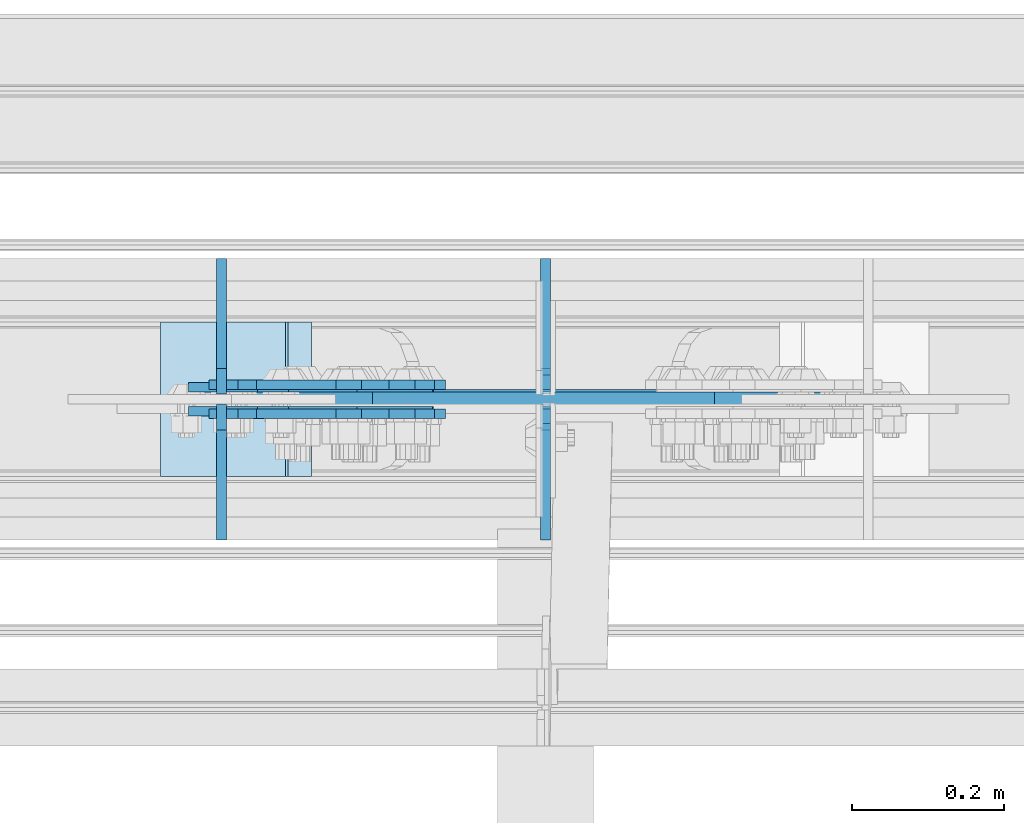
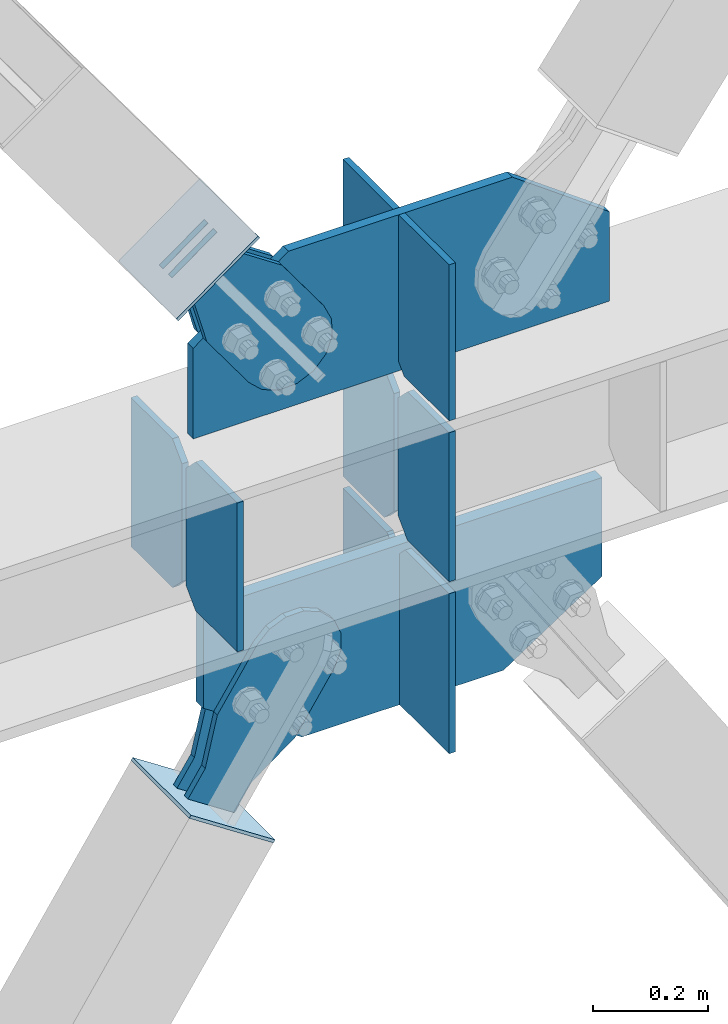
# One storey, part 3647 of 3843: 16 plates, 7 elements without a shape of their own.
"""IFC2X3 building model written with IfcOpenShell, lengths in millimetres."""

from ifc_helpers import new_model, si_unit, frame, origin_with_axes, place, context, subcontext, project, spatial, faceted_brep, material, type_object, element, aggregate, save


model = new_model("IFC2X3")

# Units and contexts
model_context = context("Model", 3, precision=1e-05, world=origin_with_axes())
body_context = subcontext(model_context, "Body", "Model", "MODEL_VIEW")
ifc_project = project(units=[si_unit("LENGTHUNIT", "METRE", prefix="MILLI"), si_unit("AREAUNIT", "SQUARE_METRE"), si_unit("VOLUMEUNIT", "CUBIC_METRE"), si_unit("MASSUNIT", "GRAM", prefix="KILO"), si_unit("TIMEUNIT", "SECOND"), si_unit("PLANEANGLEUNIT", "RADIAN"), si_unit("SOLIDANGLEUNIT", "STERADIAN"), si_unit("THERMODYNAMICTEMPERATUREUNIT", "DEGREE_CELSIUS"), si_unit("LUMINOUSINTENSITYUNIT", "LUMEN")], contexts=[model_context])

# Site, building, storey
site_placement = place(None, origin_with_axes())
site = spatial("IfcSite", under=ifc_project, at=site_placement, CompositionType="ELEMENT")
building_placement = place(site_placement, origin_with_axes())
building = spatial("IfcBuilding", under=site, at=building_placement, Name="Undefined", CompositionType="ELEMENT")
storey_placement = place(building_placement, origin_with_axes())
storey = spatial("IfcBuildingStorey", under=building, at=storey_placement, Name="Undefined", CompositionType="ELEMENT", Elevation=0.0)

# Assembly, plates
assembly_1_placement = place(storey_placement, origin_with_axes())
assembly_1 = element("IfcElementAssembly", 1, at=assembly_1_placement, inside=storey, Name="BEAM", AssemblyPlace="NOTDEFINED", PredefinedType="RIGID_FRAME")
ifc_material_1 = material(Name="STEEL/A572-50")
plate_type_1 = type_object("IfcPlateType", PredefinedType="NOTDEFINED")
plate_1_placement = place(assembly_1_placement, frame((80903.4641858708, 104566.24375, 36093.4), z_axis=(0.0, 1.0, 0.0), x_axis=(0.0, 0.0, 1.0)))
plate_1 = element("IfcPlate", 2, at=plate_1_placement, type_object=plate_type_1, material=ifc_material_1, Name="CB_BEAM", context=body_context, shape_type="Brep", body=[
    faceted_brep([(0.0, -6.34999999999854, 33.3375015258789), (0.0, -6.34999999999854, 178.59375), (0.0, 6.34999999999854, 178.59375), (0.0, 6.34999999999854, 33.3375015258789), (317.499999999985, -6.34999999999854, 178.59375), (317.499999999985, 6.34999999999854, 178.59375), (317.499999999985, -6.34999999999854, 33.3375015258789), (317.499999999985, 6.34999999999854, 33.3375015258789), (284.162498474107, -6.34999999999854, 0.0), (284.162498474107, 6.34999999999854, 0.0), (33.3375015258789, -6.34999999999854, 0.0), (33.3375015258789, 6.34999999999854, 0.0)], [[[0, 1, 2, 3]], [[1, 4, 5, 2]], [[4, 6, 7, 5]], [[6, 8, 9, 7]], [[8, 10, 11, 9]], [[10, 0, 3, 11]], [[5, 7, 9, 11, 3, 2]], [[10, 8, 6, 4, 1, 0]]]),
])
plate_2_placement = place(assembly_1_placement, frame((80903.4641858708, 104551.95625, 36093.4), z_axis=(0.0, -1.0, 0.0), x_axis=(0.0, 0.0, 1.0)))
plate_2 = element("IfcPlate", 3, at=plate_2_placement, type_object=plate_type_1, material=ifc_material_1, Name="CB_BEAM", context=body_context, shape_type="Brep", body=[
    faceted_brep([(0.0, -6.34999999999854, 33.3375015258789), (0.0, -6.34999999999854, 178.59375), (0.0, 6.34999999999854, 178.59375), (0.0, 6.34999999999854, 33.3375015258789), (317.499999999985, -6.34999999999854, 178.59375), (317.499999999985, 6.34999999999854, 178.59375), (317.499999999985, -6.34999999999854, 33.3375015258789), (317.499999999985, 6.34999999999854, 33.3375015258789), (284.162498474107, -6.34999999999854, 0.0), (284.162498474107, 6.34999999999854, 0.0), (33.3375015258789, -6.34999999999854, 0.0), (33.3375015258789, 6.34999999999854, 0.0)], [[[0, 1, 2, 3]], [[1, 4, 5, 2]], [[4, 6, 7, 5]], [[6, 8, 9, 7]], [[8, 10, 11, 9]], [[10, 0, 3, 11]], [[5, 7, 9, 11, 3, 2]], [[10, 8, 6, 4, 1, 0]]]),
])
plate_3_placement = place(assembly_1_placement, frame((81330.8000009417, 104566.24375, 36093.4), z_axis=(0.0, 1.0, 0.0), x_axis=(0.0, 0.0, 1.0)))
plate_3 = element("IfcPlate", 4, at=plate_3_placement, type_object=plate_type_1, material=ifc_material_1, Name="CB_BEAM", context=body_context, shape_type="Brep", body=[
    faceted_brep([(0.0, -6.34999999999854, 33.3375015258789), (0.0, -6.34999999999854, 178.59375), (0.0, 6.34999999999854, 178.59375), (0.0, 6.34999999999854, 33.3375015258789), (317.499999999985, -6.34999999999854, 178.59375), (317.499999999985, 6.34999999999854, 178.59375), (317.499999999985, -6.34999999999854, 33.3375015258789), (317.499999999985, 6.34999999999854, 33.3375015258789), (284.162498474107, -6.34999999999854, 0.0), (284.162498474107, 6.34999999999854, 0.0), (33.3375015258789, -6.34999999999854, 0.0), (33.3375015258789, 6.34999999999854, 0.0)], [[[0, 1, 2, 3]], [[1, 4, 5, 2]], [[4, 6, 7, 5]], [[6, 8, 9, 7]], [[8, 10, 11, 9]], [[10, 0, 3, 11]], [[5, 7, 9, 11, 3, 2]], [[10, 8, 6, 4, 1, 0]]]),
])
plate_4_placement = place(assembly_1_placement, frame((81330.8000009417, 104551.95625, 36093.4), z_axis=(0.0, -1.0, 0.0), x_axis=(0.0, 0.0, 1.0)))
plate_4 = element("IfcPlate", 5, at=plate_4_placement, type_object=plate_type_1, material=ifc_material_1, Name="CB_BEAM", context=body_context, shape_type="Brep", body=[
    faceted_brep([(0.0, -6.34999999999854, 33.3375015258789), (0.0, -6.34999999999854, 178.59375), (0.0, 6.34999999999854, 178.59375), (0.0, 6.34999999999854, 33.3375015258789), (317.499999999985, -6.34999999999854, 178.59375), (317.499999999985, 6.34999999999854, 178.59375), (317.499999999985, -6.34999999999854, 33.3375015258789), (317.499999999985, 6.34999999999854, 33.3375015258789), (284.162498474107, -6.34999999999854, 0.0), (284.162498474107, 6.34999999999854, 0.0), (33.3375015258789, -6.34999999999854, 0.0), (33.3375015258789, 6.34999999999854, 0.0)], [[[0, 1, 2, 3]], [[1, 4, 5, 2]], [[4, 6, 7, 5]], [[6, 8, 9, 7]], [[8, 10, 11, 9]], [[10, 0, 3, 11]], [[5, 7, 9, 11, 3, 2]], [[10, 8, 6, 4, 1, 0]]]),
])
plate_type_2 = type_object("IfcPlateType", PredefinedType="NOTDEFINED")
plate_5_placement = place(assembly_1_placement, frame((81330.8000009417, 104571.8, 35726.6875), z_axis=(0.0, 1.0, 0.0), x_axis=(0.0, 0.0, 1.0)))
plate_5 = element("IfcPlate", 6, at=plate_5_placement, type_object=plate_type_2, material=ifc_material_1, Name="CB", context=body_context, shape_type="Brep", body=[
    faceted_brep([(0.0, -6.3499999046162, 0.0), (0.0, -6.34999999999854, 173.037500000006), (0.0, 6.34999999999854, 173.037500000006), (7.27595761418343e-12, 6.3499999046162, 0.0), (341.302418280502, -6.35000000000582, 173.037500000006), (341.302418280502, 6.35000000000582, 173.037500000006), (341.302418280502, -6.35000000000582, 19.0499992370605), (341.302418280502, 6.35000000000582, 19.0499992370605), (322.252419043441, -6.35000000000582, 0.0), (322.252419043441, 6.35000000000582, 0.0)], [[[0, 1, 2, 3]], [[1, 4, 5, 2]], [[4, 6, 7, 5]], [[6, 8, 9, 7]], [[8, 0, 3, 9]], [[5, 7, 9, 3, 2]], [[8, 6, 4, 1, 0]]]),
])
plate_6_placement = place(assembly_1_placement, frame((81330.8000009417, 104546.4, 35726.6875), z_axis=(0.0, -1.0, 0.0), x_axis=(0.0, 0.0, 1.0)))
plate_6 = element("IfcPlate", 7, at=plate_6_placement, type_object=plate_type_2, material=ifc_material_1, Name="CB", context=body_context, shape_type="Brep", body=[
    faceted_brep([(0.0, -6.3499999046162, 0.0), (0.0, -6.34999999999854, 173.037500000006), (0.0, 6.34999999999854, 173.037500000006), (7.27595761418343e-12, 6.3499999046162, 0.0), (341.302418280502, -6.35000000000582, 173.037500000006), (341.302418280502, 6.35000000000582, 173.037500000006), (341.302418280502, -6.35000000000582, 19.0499992370605), (341.302418280502, 6.35000000000582, 19.0499992370605), (322.252419043441, -6.35000000000582, 0.0), (322.252419043441, 6.35000000000582, 0.0)], [[[0, 1, 2, 3]], [[1, 4, 5, 2]], [[4, 6, 7, 5]], [[6, 8, 9, 7]], [[8, 0, 3, 9]], [[5, 7, 9, 3, 2]], [[8, 6, 4, 1, 0]]]),
])
plate_type_3 = type_object("IfcPlateType", PredefinedType="NOTDEFINED")
plate_7_placement = place(assembly_1_placement, frame((80909.8138656546, 104559.1, 36436.3), z_axis=(1.0, 0.0, 0.0), x_axis=(0.0, 0.0, 1.0)))
plate_7 = element("IfcPlate", 8, at=plate_7_placement, type_object=plate_type_3, material=ifc_material_1, Name="CB", context=body_context, shape_type="Brep", body=[
    faceted_brep([(0.0, -9.52500000000146, 0.0), (0.0, -9.52499999999418, 840.106454561566), (0.0, 9.52499999999418, 840.106454561566), (0.0, 9.52500000000146, 0.0), (190.305685780353, -9.52499999999418, 840.106454561566), (190.305685780353, 9.52499999999418, 840.106454561566), (332.810611949739, -9.52499999999418, 643.900231879976), (332.810611949739, 9.52499999999418, 643.900231879976), (332.810611949739, -9.52499999999418, 427.336135287071), (332.810611949739, 9.52499999999418, 427.336135287071), (332.810611949739, -9.52499999999418, 192.669227863458), (332.810611949739, 9.52499999999418, 192.669227863458), (192.874611365543, -9.52499999999418, 0.0), (192.874611365543, 9.52499999999418, 0.0)], [[[0, 1, 2, 3]], [[1, 4, 5, 2]], [[4, 6, 7, 5]], [[6, 8, 9, 7]], [[8, 10, 11, 9]], [[10, 12, 13, 11]], [[12, 0, 3, 13]], [[5, 7, 9, 11, 13, 3, 2]], [[12, 10, 8, 6, 4, 1, 0]]]),
])

# Assembly, plate
assembly_2_placement = place(storey_placement, origin_with_axes())
assembly_2 = element("IfcElementAssembly", 9, at=assembly_2_placement, inside=storey, Name="Plate", AssemblyPlace="NOTDEFINED", PredefinedType="RIGID_FRAME")
ifc_material_2 = material(Name="STEEL/A36")
plate_type_4 = type_object("IfcPlateType", PredefinedType="NOTDEFINED")
plate_8_placement = place(assembly_2_placement, frame((80825.0548352249, 104660.7, 36775.5895057163), z_axis=(0.809109618324204, 0.0, 0.58765774523549), x_axis=(0.0, -1.0, 0.0)))
plate_8 = element("IfcPlate", 10, at=plate_8_placement, type_object=plate_type_4, material=ifc_material_2, Name="Plate", context=body_context, shape_type="Brep", body=[
    faceted_brep([(0.0, -3.17499999999927, 0.0), (0.0, -3.17500000043947, 203.200000001736), (0.0, 3.1749999995518, 203.200000001743), (0.0, 3.17499999999927, 0.0), (203.200000000012, -3.17500000043947, 203.200000001736), (203.200000000012, 3.1749999995518, 203.200000001743), (203.199996948242, -3.17499999999927, 0.0), (203.199996948242, 3.17499999999927, 0.0)], [[[0, 1, 2, 3]], [[1, 4, 5, 2]], [[4, 6, 7, 5]], [[6, 0, 3, 7]], [[5, 7, 3, 2]], [[6, 4, 1, 0]]]),
])
aggregate(assembly_2, [plate_8])

assembly_3_placement = place(storey_placement, origin_with_axes())
assembly_3 = element("IfcElementAssembly", 11, at=assembly_3_placement, inside=storey, Name="Plate", AssemblyPlace="NOTDEFINED", PredefinedType="RIGID_FRAME")
plate_9_placement = place(assembly_3_placement, frame((81020.3403620731, 104457.5, 35595.744008217), z_axis=(-0.835270498690032, 0.0, 0.549839243795953), x_axis=(0.0, 1.0, 0.0)))
plate_9 = element("IfcPlate", 12, at=plate_9_placement, type_object=plate_type_4, material=ifc_material_2, Name="Plate", context=body_context, shape_type="Brep", body=[
    faceted_brep([(0.0, -3.17499999999927, 0.0), (0.0, -3.17500000043947, 203.200000001736), (0.0, 3.1749999995518, 203.200000001743), (0.0, 3.17499999999927, 0.0), (203.200000000012, -3.17500000043947, 203.200000001736), (203.200000000012, 3.1749999995518, 203.200000001743), (203.199996948242, -3.17499999999927, 0.0), (203.199996948242, 3.17499999999927, 0.0)], [[[0, 1, 2, 3]], [[1, 4, 5, 2]], [[4, 6, 7, 5]], [[6, 0, 3, 7]], [[5, 7, 3, 2]], [[6, 4, 1, 0]]]),
])
aggregate(assembly_3, [plate_9])

assembly_4_placement = place(storey_placement, origin_with_axes())
assembly_4 = element("IfcElementAssembly", 13, at=assembly_4_placement, inside=storey, AssemblyPlace="NOTDEFINED", PredefinedType="RIGID_FRAME")
plate_type_5 = type_object("IfcPlateType", PredefinedType="NOTDEFINED")
plate_10_placement = place(assembly_4_placement, frame((80950.7795124551, 104574.975, 36870.8276274707), z_axis=(-0.80910961832422, 0.0, -0.587657745235469), x_axis=(0.587657745235471, 0.0, -0.809109618324219)))
plate_10 = element("IfcPlate", 14, at=plate_10_placement, type_object=plate_type_5, material=ifc_material_2, context=body_context, shape_type="Brep", body=[
    faceted_brep([(0.0, -6.3499999046162, 0.0), (4.9622030928731e-09, -6.35000000000582, 112.184930798256), (4.9622030928731e-09, 6.35000000000582, 112.184930798256), (7.27595761418343e-12, 6.3499999046162, 0.0), (69.8500000038475, -6.35000000000582, 112.184930798168), (69.8500000038475, 6.35000000000582, 112.184930798168), (171.450000003882, -6.35000000000582, 149.754965398664), (171.450000003882, 6.35000000000582, 149.754965398664), (315.219242329083, -6.35000000000582, 149.754965398519), (315.219242329083, 6.35000000000582, 149.754965398519), (351.06232873004, -6.35000000000582, 142.625332228003), (351.06232873004, 6.35000000000582, 142.625332228003), (381.448630144558, -6.35000000000582, 122.321854736569), (381.448630144558, 6.35000000000582, 122.321854736569), (401.752107634529, -6.35000000000582, 91.9355533209819), (401.752107634529, 6.35000000000582, 91.9355533209819), (408.881740803365, -6.35000000000582, 56.0924638688084), (408.881740803365, 6.35000000000582, 56.0924638688084), (401.75210763223, -6.35000000000582, 20.2493774701215), (401.75210763223, 6.35000000000582, 20.2493774701215), (381.448630141909, -6.35000000000582, -10.1369239423584), (381.448630141909, 6.35000000000582, -10.1369239423584), (351.062328728673, -6.35000000000582, -30.4404014313986), (351.062328728673, 6.35000000000582, -30.4404014313986), (315.219240800725, -6.35000000000582, -37.5700346009617), (315.219240800725, 6.35000000000582, -37.5700346009617), (171.449999995632, -6.35000000000582, -37.5700346008307), (171.449999995632, 6.35000000000582, -37.5700346008307), (69.8499999985434, -6.35000000000582, -8.73114913702011e-11), (69.8499999985434, 6.35000000000582, -8.73114913702011e-11)], [[[0, 1, 2, 3]], [[1, 4, 5, 2]], [[4, 6, 7, 5]], [[6, 8, 9, 7]], [[8, 10, 11, 9]], [[10, 12, 13, 11]], [[12, 14, 15, 13]], [[14, 16, 17, 15]], [[16, 18, 19, 17]], [[18, 20, 21, 19]], [[20, 22, 23, 21]], [[22, 24, 25, 23]], [[24, 26, 27, 25]], [[26, 28, 29, 27]], [[28, 0, 3, 29]], [[5, 7, 9, 11, 13, 15, 17, 19, 21, 23, 25, 27, 29, 3, 2]], [[28, 26, 24, 22, 20, 18, 16, 14, 12, 10, 8, 6, 4, 1, 0]]]),
])
aggregate(assembly_4, [plate_10])

assembly_5_placement = place(storey_placement, origin_with_axes())
assembly_5 = element("IfcElementAssembly", 15, at=assembly_5_placement, inside=storey, AssemblyPlace="NOTDEFINED", PredefinedType="RIGID_FRAME")
plate_11_placement = place(assembly_5_placement, frame((80950.7795124551, 104543.225, 36870.8276274707), z_axis=(-0.80910961832422, 0.0, -0.587657745235469), x_axis=(0.587657745235471, 0.0, -0.809109618324219)))
plate_11 = element("IfcPlate", 16, at=plate_11_placement, type_object=plate_type_5, material=ifc_material_2, context=body_context, shape_type="Brep", body=[
    faceted_brep([(0.0, -6.3499999046162, 0.0), (4.9622030928731e-09, -6.35000000000582, 112.184930798256), (4.9622030928731e-09, 6.35000000000582, 112.184930798256), (7.27595761418343e-12, 6.3499999046162, 0.0), (69.8500000038475, -6.35000000000582, 112.184930798168), (69.8500000038475, 6.35000000000582, 112.184930798168), (171.450000003882, -6.35000000000582, 149.754965398664), (171.450000003882, 6.35000000000582, 149.754965398664), (315.219242329083, -6.35000000000582, 149.754965398519), (315.219242329083, 6.35000000000582, 149.754965398519), (351.06232873004, -6.35000000000582, 142.625332228003), (351.06232873004, 6.35000000000582, 142.625332228003), (381.448630144558, -6.35000000000582, 122.321854736569), (381.448630144558, 6.35000000000582, 122.321854736569), (401.752107634529, -6.35000000000582, 91.9355533209819), (401.752107634529, 6.35000000000582, 91.9355533209819), (408.881740803365, -6.35000000000582, 56.0924638688084), (408.881740803365, 6.35000000000582, 56.0924638688084), (401.75210763223, -6.35000000000582, 20.2493774701215), (401.75210763223, 6.35000000000582, 20.2493774701215), (381.448630141909, -6.35000000000582, -10.1369239423584), (381.448630141909, 6.35000000000582, -10.1369239423584), (351.062328728673, -6.35000000000582, -30.4404014313986), (351.062328728673, 6.35000000000582, -30.4404014313986), (315.219240800725, -6.35000000000582, -37.5700346009617), (315.219240800725, 6.35000000000582, -37.5700346009617), (171.449999995632, -6.35000000000582, -37.5700346008307), (171.449999995632, 6.35000000000582, -37.5700346008307), (69.8499999985434, -6.35000000000582, -8.73114913702011e-11), (69.8499999985434, 6.35000000000582, -8.73114913702011e-11)], [[[0, 1, 2, 3]], [[1, 4, 5, 2]], [[4, 6, 7, 5]], [[6, 8, 9, 7]], [[8, 10, 11, 9]], [[10, 12, 13, 11]], [[12, 14, 15, 13]], [[14, 16, 17, 15]], [[16, 18, 19, 17]], [[18, 20, 21, 19]], [[20, 22, 23, 21]], [[22, 24, 25, 23]], [[24, 26, 27, 25]], [[26, 28, 29, 27]], [[28, 0, 3, 29]], [[5, 7, 9, 11, 13, 15, 17, 19, 21, 23, 25, 27, 29, 3, 2]], [[28, 26, 24, 22, 20, 18, 16, 14, 12, 10, 8, 6, 4, 1, 0]]]),
])
aggregate(assembly_5, [plate_11])

assembly_6_placement = place(storey_placement, origin_with_axes())
assembly_6 = element("IfcElementAssembly", 17, at=assembly_6_placement, inside=storey, AssemblyPlace="NOTDEFINED", PredefinedType="RIGID_FRAME")
plate_12_placement = place(assembly_6_placement, frame((80980.5835211669, 104578.15, 35618.1138529607), z_axis=(-0.835270498690032, 0.0, 0.549839243795953), x_axis=(0.549839243795952, 0.0, 0.835270498690032)))
plate_12 = element("IfcPlate", 18, at=plate_12_placement, type_object=plate_type_5, material=ifc_material_2, context=body_context, shape_type="Brep", body=[
    faceted_brep([(0.0, -6.3499999046162, 0.0), (4.9622030928731e-09, -6.35000000000582, 112.184930798256), (4.9622030928731e-09, 6.35000000000582, 112.184930798256), (7.27595761418343e-12, 6.3499999046162, 0.0), (69.8500000038475, -6.35000000000582, 112.184930798168), (69.8500000038475, 6.35000000000582, 112.184930798168), (171.450000003882, -6.35000000000582, 149.754965398664), (171.450000003882, 6.35000000000582, 149.754965398664), (315.219242329083, -6.35000000000582, 149.754965398519), (315.219242329083, 6.35000000000582, 149.754965398519), (351.06232873004, -6.35000000000582, 142.625332228003), (351.06232873004, 6.35000000000582, 142.625332228003), (381.448630144558, -6.35000000000582, 122.321854736569), (381.448630144558, 6.35000000000582, 122.321854736569), (401.752107634529, -6.35000000000582, 91.9355533209819), (401.752107634529, 6.35000000000582, 91.9355533209819), (408.881740803365, -6.35000000000582, 56.0924638688084), (408.881740803365, 6.35000000000582, 56.0924638688084), (401.75210763223, -6.35000000000582, 20.2493774701215), (401.75210763223, 6.35000000000582, 20.2493774701215), (381.448630141909, -6.35000000000582, -10.1369239423584), (381.448630141909, 6.35000000000582, -10.1369239423584), (351.062328728673, -6.35000000000582, -30.4404014313986), (351.062328728673, 6.35000000000582, -30.4404014313986), (315.219240800725, -6.35000000000582, -37.5700346009617), (315.219240800725, 6.35000000000582, -37.5700346009617), (171.449999995632, -6.35000000000582, -37.5700346008307), (171.449999995632, 6.35000000000582, -37.5700346008307), (69.8499999985434, -6.35000000000582, -8.73114913702011e-11), (69.8499999985434, 6.35000000000582, -8.73114913702011e-11)], [[[0, 1, 2, 3]], [[1, 4, 5, 2]], [[4, 6, 7, 5]], [[6, 8, 9, 7]], [[8, 10, 11, 9]], [[10, 12, 13, 11]], [[12, 14, 15, 13]], [[14, 16, 17, 15]], [[16, 18, 19, 17]], [[18, 20, 21, 19]], [[20, 22, 23, 21]], [[22, 24, 25, 23]], [[24, 26, 27, 25]], [[26, 28, 29, 27]], [[28, 0, 3, 29]], [[5, 7, 9, 11, 13, 15, 17, 19, 21, 23, 25, 27, 29, 3, 2]], [[28, 26, 24, 22, 20, 18, 16, 14, 12, 10, 8, 6, 4, 1, 0]]]),
])
aggregate(assembly_6, [plate_12])

assembly_7_placement = place(storey_placement, origin_with_axes())
assembly_7 = element("IfcElementAssembly", 19, at=assembly_7_placement, inside=storey, AssemblyPlace="NOTDEFINED", PredefinedType="RIGID_FRAME")
plate_13_placement = place(assembly_7_placement, frame((80980.5835211669, 104540.05, 35618.1138529607), z_axis=(-0.835270498690032, 0.0, 0.549839243795953), x_axis=(0.549839243795952, 0.0, 0.835270498690032)))
plate_13 = element("IfcPlate", 20, at=plate_13_placement, type_object=plate_type_5, material=ifc_material_2, context=body_context, shape_type="Brep", body=[
    faceted_brep([(0.0, -6.3499999046162, 0.0), (4.9622030928731e-09, -6.35000000000582, 112.184930798256), (4.9622030928731e-09, 6.35000000000582, 112.184930798256), (7.27595761418343e-12, 6.3499999046162, 0.0), (69.8500000038475, -6.35000000000582, 112.184930798168), (69.8500000038475, 6.35000000000582, 112.184930798168), (171.450000003882, -6.35000000000582, 149.754965398664), (171.450000003882, 6.35000000000582, 149.754965398664), (315.219242329083, -6.35000000000582, 149.754965398519), (315.219242329083, 6.35000000000582, 149.754965398519), (351.06232873004, -6.35000000000582, 142.625332228003), (351.06232873004, 6.35000000000582, 142.625332228003), (381.448630144558, -6.35000000000582, 122.321854736569), (381.448630144558, 6.35000000000582, 122.321854736569), (401.752107634529, -6.35000000000582, 91.9355533209819), (401.752107634529, 6.35000000000582, 91.9355533209819), (408.881740803365, -6.35000000000582, 56.0924638688084), (408.881740803365, 6.35000000000582, 56.0924638688084), (401.75210763223, -6.35000000000582, 20.2493774701215), (401.75210763223, 6.35000000000582, 20.2493774701215), (381.448630141909, -6.35000000000582, -10.1369239423584), (381.448630141909, 6.35000000000582, -10.1369239423584), (351.062328728673, -6.35000000000582, -30.4404014313986), (351.062328728673, 6.35000000000582, -30.4404014313986), (315.219240800725, -6.35000000000582, -37.5700346009617), (315.219240800725, 6.35000000000582, -37.5700346009617), (171.449999995632, -6.35000000000582, -37.5700346008307), (171.449999995632, 6.35000000000582, -37.5700346008307), (69.8499999985434, -6.35000000000582, -8.73114913702011e-11), (69.8499999985434, 6.35000000000582, -8.73114913702011e-11)], [[[0, 1, 2, 3]], [[1, 4, 5, 2]], [[4, 6, 7, 5]], [[6, 8, 9, 7]], [[8, 10, 11, 9]], [[10, 12, 13, 11]], [[12, 14, 15, 13]], [[14, 16, 17, 15]], [[16, 18, 19, 17]], [[18, 20, 21, 19]], [[20, 22, 23, 21]], [[22, 24, 25, 23]], [[24, 26, 27, 25]], [[26, 28, 29, 27]], [[28, 0, 3, 29]], [[5, 7, 9, 11, 13, 15, 17, 19, 21, 23, 25, 27, 29, 3, 2]], [[28, 26, 24, 22, 20, 18, 16, 14, 12, 10, 8, 6, 4, 1, 0]]]),
])
aggregate(assembly_7, [plate_13])

# Plate
plate_type_6 = type_object("IfcPlateType", PredefinedType="NOTDEFINED")
plate_14_placement = place(assembly_1_placement, frame((80928.5516840697, 104559.1, 35857.6280536935), z_axis=(1.0, 0.0, 0.0), x_axis=(0.0, 0.0, 1.0)))
plate_14 = element("IfcPlate", 21, at=plate_14_placement, type_object=plate_type_6, material=ifc_material_1, Name="CB", context=body_context, shape_type="Brep", body=[
    faceted_brep([(0.0, -12.6999999999971, 0.0), (-130.930471973988, -12.6999999999971, 198.898790607273), (-130.930471973988, 12.6999999999971, 198.898790607273), (0.0, 12.6999999999971, 0.0), (-130.930471973988, -12.6999999999971, 408.598316755364), (-130.930471973988, 12.6999999999971, 408.598316755364), (-130.930471973988, -12.6999999999971, 605.597844360076), (-130.930471973988, 12.6999999999971, 605.597844360076), (-2.04508251044899e-06, -12.6999999999971, 804.496631860646), (-2.04508251044899e-06, 12.6999999999971, 804.496631860646), (210.371946306514, -12.6999999999971, 804.496631860646), (210.371946306514, 12.6999999999971, 804.496631860646), (210.371946306514, -12.6999999999971, 0.0), (210.371946306514, 12.6999999999971, 0.0)], [[[0, 1, 2, 3]], [[1, 4, 5, 2]], [[4, 6, 7, 5]], [[6, 8, 9, 7]], [[8, 10, 11, 9]], [[10, 12, 13, 11]], [[12, 0, 3, 13]], [[5, 7, 9, 11, 13, 3, 2]], [[12, 10, 8, 6, 4, 1, 0]]]),
])

plate_type_7 = type_object("IfcPlateType", PredefinedType="NOTDEFINED")
plate_15_placement = place(assembly_1_placement, frame((81330.7999982703, 104568.625, 36436.3), z_axis=(0.0, 1.0, 0.0), x_axis=(0.0, 0.0, 1.0)))
plate_15 = element("IfcPlate", 22, at=plate_15_placement, type_object=plate_type_7, material=ifc_material_1, Name="CB", context=body_context, shape_type="Brep", body=[
    faceted_brep([(0.0, -6.34999999999854, 19.0499992370605), (0.0, -6.35000000000582, 176.212500000009), (0.0, 6.35000000000582, 176.212500000009), (0.0, 6.34999999999854, 19.0499992370605), (332.810611949739, -6.35000000000582, 176.212500000009), (332.810611949739, 6.35000000000582, 176.212500000009), (332.810611949739, -6.35000000000582, 0.0), (332.810611949739, 6.35000000000582, 0.0), (19.0499992370605, -6.34999999999854, 0.0), (19.0499992370605, 6.34999999999854, 0.0)], [[[0, 1, 2, 3]], [[1, 4, 5, 2]], [[4, 6, 7, 5]], [[6, 8, 9, 7]], [[8, 0, 3, 9]], [[5, 7, 9, 3, 2]], [[8, 6, 4, 1, 0]]]),
])

plate_16_placement = place(assembly_1_placement, frame((81330.7999982703, 104549.575, 36436.3), z_axis=(0.0, -1.0, 0.0), x_axis=(0.0, 0.0, 1.0)))
plate_16 = element("IfcPlate", 23, at=plate_16_placement, type_object=plate_type_7, material=ifc_material_1, Name="CB", context=body_context, shape_type="Brep", body=[
    faceted_brep([(0.0, -6.34999999999854, 19.0499992370605), (0.0, -6.35000000000582, 176.212500000009), (0.0, 6.35000000000582, 176.212500000009), (0.0, 6.34999999999854, 19.0499992370605), (332.810611949739, -6.35000000000582, 176.212500000009), (332.810611949739, 6.35000000000582, 176.212500000009), (332.810611949739, -6.35000000000582, 0.0), (332.810611949739, 6.35000000000582, 0.0), (19.0499992370605, -6.34999999999854, 0.0), (19.0499992370605, 6.34999999999854, 0.0)], [[[0, 1, 2, 3]], [[1, 4, 5, 2]], [[4, 6, 7, 5]], [[6, 8, 9, 7]], [[8, 0, 3, 9]], [[5, 7, 9, 3, 2]], [[8, 6, 4, 1, 0]]]),
])

aggregate(assembly_1, [plate_1, plate_2, plate_3, plate_4, plate_5, plate_6, plate_14, plate_15, plate_16, plate_7])

save(model, "model.ifc")
